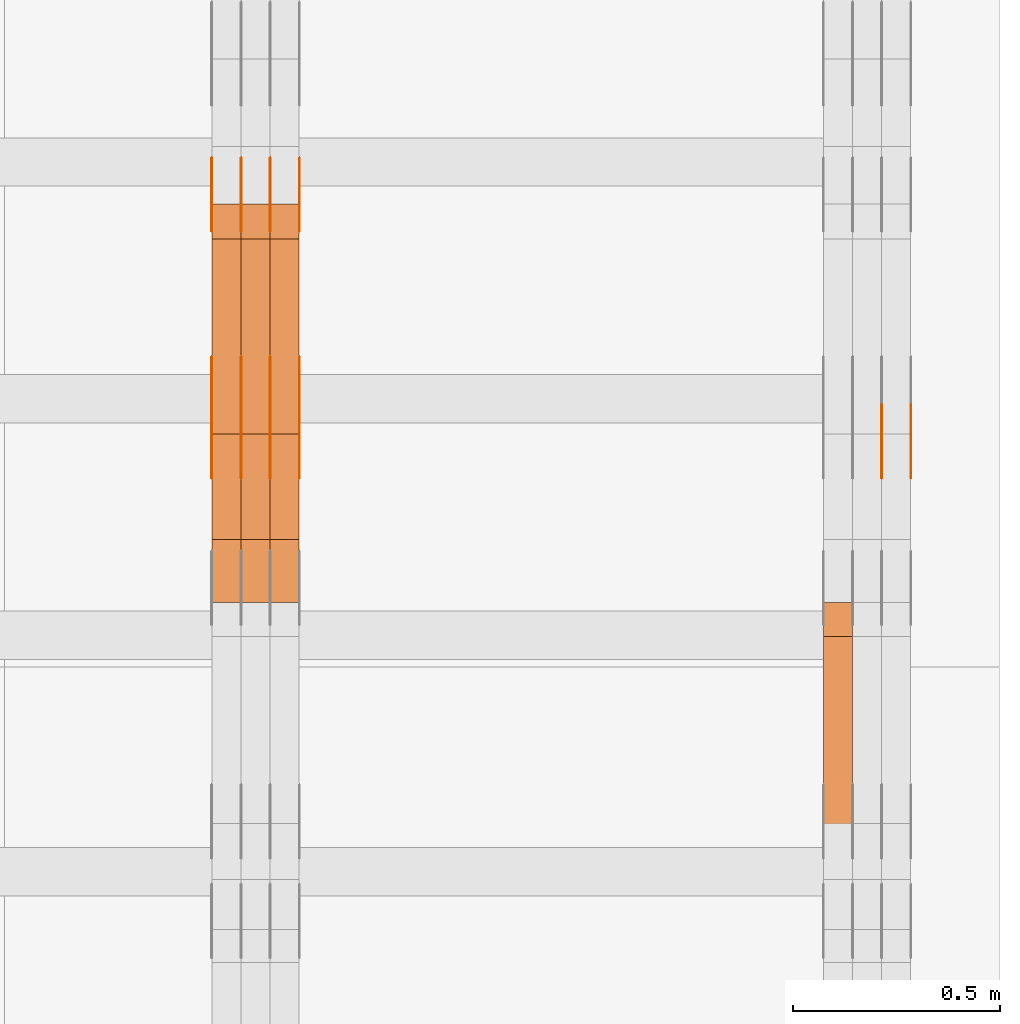
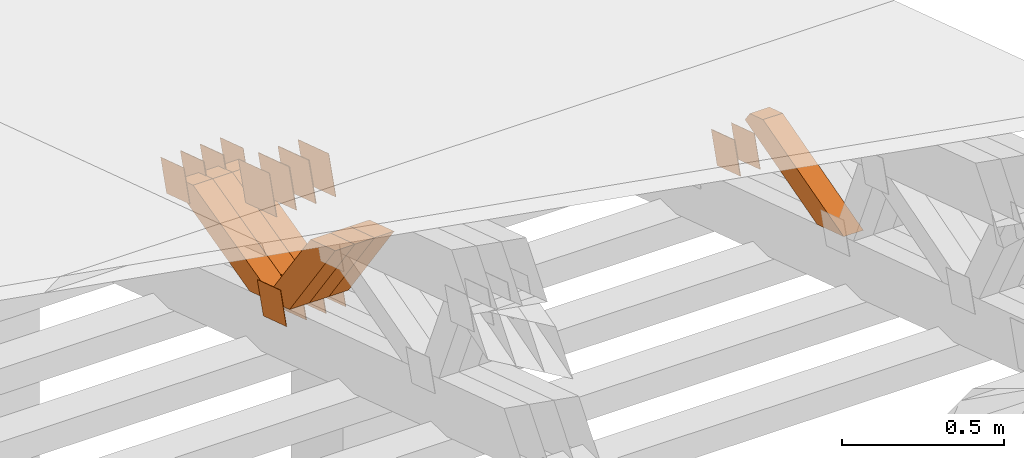
# One storey, part 373 of 385: 28 proxies.
"""IFC2X3 building model written with IfcOpenShell, lengths in millimetres."""

from ifc_helpers import new_model, entity, si_unit, converted_unit, derived_unit, direction, frame, origin, place, context, subcontext, project, spatial, polyline, outline, extrude, source, transform, mapped, material, type_object, type_shapes, element, save


model = new_model("IFC2X3")

# Units and contexts
model_context = context("Model", 3, precision=0.01, world=origin(), true_north=direction((6.12303176911189e-17, 1.0)))
body_context = subcontext(model_context, "Body", "Model", "MODEL_VIEW")
ifc_project = project(units=[si_unit("LENGTHUNIT", "METRE", prefix="MILLI"), si_unit("AREAUNIT", "SQUARE_METRE"), si_unit("VOLUMEUNIT", "CUBIC_METRE"), converted_unit("PLANEANGLEUNIT", "DEGREE", entity("IfcRatioMeasure", 0.0174532925199433), si_unit("PLANEANGLEUNIT", "RADIAN"), dimensions=[0, 0, 0, 0, 0, 0, 0]), si_unit("MASSUNIT", "GRAM", prefix="KILO"), derived_unit("MASSDENSITYUNIT", [(si_unit("MASSUNIT", "GRAM", prefix="KILO"), 1), (si_unit("LENGTHUNIT", "METRE"), -3)]), si_unit("TIMEUNIT", "SECOND"), si_unit("FREQUENCYUNIT", "HERTZ"), si_unit("THERMODYNAMICTEMPERATUREUNIT", "DEGREE_CELSIUS"), derived_unit("THERMALTRANSMITTANCEUNIT", [(si_unit("MASSUNIT", "GRAM", prefix="KILO"), 1), (si_unit("THERMODYNAMICTEMPERATUREUNIT", "KELVIN"), -1), (si_unit("TIMEUNIT", "SECOND"), -3)]), derived_unit("VOLUMETRICFLOWRATEUNIT", [(si_unit("LENGTHUNIT", "METRE"), 3), (si_unit("TIMEUNIT", "SECOND"), -1)]), si_unit("ELECTRICCURRENTUNIT", "AMPERE"), si_unit("ELECTRICVOLTAGEUNIT", "VOLT"), si_unit("POWERUNIT", "WATT"), si_unit("FORCEUNIT", "NEWTON", prefix="KILO"), si_unit("ILLUMINANCEUNIT", "LUX"), si_unit("LUMINOUSFLUXUNIT", "LUMEN"), si_unit("LUMINOUSINTENSITYUNIT", "CANDELA"), derived_unit("USERDEFINED", [(si_unit("MASSUNIT", "GRAM", prefix="KILO"), -1), (si_unit("LENGTHUNIT", "METRE"), -2), (si_unit("TIMEUNIT", "SECOND"), 3), (si_unit("LUMINOUSFLUXUNIT", "LUMEN"), 1)]), derived_unit("LINEARVELOCITYUNIT", [(si_unit("LENGTHUNIT", "METRE"), 1), (si_unit("TIMEUNIT", "SECOND"), -1)]), si_unit("PRESSUREUNIT", "PASCAL"), derived_unit("USERDEFINED", [(si_unit("LENGTHUNIT", "METRE"), -2), (si_unit("MASSUNIT", "GRAM", prefix="KILO"), 1), (si_unit("TIMEUNIT", "SECOND"), -2)])], contexts=[model_context])

# Site, building, storey
site_placement = place(None, origin())
site = spatial("IfcSite", under=ifc_project, at=site_placement, CompositionType="ELEMENT")
building_placement = place(site_placement, origin())
building = spatial("IfcBuilding", under=site, at=building_placement, CompositionType="ELEMENT")
storey_placement = place(building_placement, origin())
storey = spatial("IfcBuildingStorey", under=building, at=storey_placement, Name="Default", CompositionType="ELEMENT", Elevation=0.0)

# Proxies
ifc_material_1 = material(Name="IfcSurfaceStyle #608302")
building_element_proxy_type_1 = type_object("IfcBuildingElementProxyType", PredefinedType="NOTDEFINED", material=ifc_material_1)
shared_shape_1 = source(origin(), body_context, "Body", "SweptSolid", [
    extrude(outline(polyline([(-74.9998841352385, -59.9999554917014), (74.9998707133932, -59.9999554917014), (74.999874704788, 59.9999554917014), (-74.9998612829427, 59.9999554917014), (-74.9998841352385, -59.9999554917014)])), frame((75.0000802775471, 60.0000306612849, 0.0), z_axis=(0.0, 0.0, 1.0), x_axis=(-1.0, 0.0, 0.0)), (0.0, 0.0, 1.0), 1.3),
])
type_shapes(building_element_proxy_type_1, [shared_shape_1])
proxy_1_placement = place(building_placement, frame((49861.3, 24338.8869142613, 728.405515087805), z_axis=(-1.0, 0.0, 0.0), x_axis=(0.0, -0.951056516295124, 0.309016994375039)))
element("IfcBuildingElementProxy", 1, at=proxy_1_placement, inside=storey, type_object=building_element_proxy_type_1, material=ifc_material_1, context=body_context, shape_type="MappedRepresentation", body=[
    mapped(shared_shape_1, transform((0.0, 0.0, 0.0), scale=1.0)),
])
ifc_material_2 = material(Name="IfcSurfaceStyle #608245")
building_element_proxy_type_2 = type_object("IfcBuildingElementProxyType", PredefinedType="NOTDEFINED", material=ifc_material_2)
shared_shape_2 = source(origin(), body_context, "Body", "SweptSolid", [
    extrude(outline(polyline([(-74.9998841352385, -59.9999554917014), (74.9998707133932, -59.9999554917014), (74.999874704788, 59.9999554917014), (-74.9998612829427, 59.9999554917014), (-74.9998841352385, -59.9999554917014)])), frame((75.0000802775471, 60.0000306612849, 0.0), z_axis=(0.0, 0.0, 1.0), x_axis=(-1.0, 0.0, 0.0)), (0.0, 0.0, 1.0), 1.3),
])
type_shapes(building_element_proxy_type_2, [shared_shape_2])
proxy_2_placement = place(building_placement, frame((49790.0, 24338.8869142613, 728.405515087805), z_axis=(-1.0, 0.0, 0.0), x_axis=(0.0, -0.951056516295124, 0.309016994375039)))
element("IfcBuildingElementProxy", 2, at=proxy_2_placement, inside=storey, type_object=building_element_proxy_type_2, material=ifc_material_2, context=body_context, shape_type="MappedRepresentation", body=[
    mapped(shared_shape_2, transform((0.0, 0.0, 0.0), scale=1.0)),
])
ifc_material_3 = material(Name="IfcSurfaceStyle #608188")
building_element_proxy_type_3 = type_object("IfcBuildingElementProxyType", PredefinedType="NOTDEFINED", material=ifc_material_3)
shared_shape_3 = source(origin(), body_context, "Body", "SweptSolid", [
    extrude(outline(polyline([(-74.9998841352385, -59.9999554917014), (74.9998707133932, -59.9999554917014), (74.999874704788, 59.9999554917014), (-74.9998612829427, 59.9999554917014), (-74.9998841352385, -59.9999554917014)])), frame((75.0000802775471, 60.0000306612849, 0.0), z_axis=(0.0, 0.0, 1.0), x_axis=(-1.0, 0.0, 0.0)), (0.0, 0.0, 1.0), 1.3),
])
type_shapes(building_element_proxy_type_3, [shared_shape_3])
proxy_3_placement = place(building_placement, frame((49791.3, 24338.8869142613, 728.405515087805), z_axis=(-1.0, 0.0, 0.0), x_axis=(0.0, -0.951056516295124, 0.309016994375039)))
element("IfcBuildingElementProxy", 3, at=proxy_3_placement, inside=storey, type_object=building_element_proxy_type_3, material=ifc_material_3, context=body_context, shape_type="MappedRepresentation", body=[
    mapped(shared_shape_3, transform((0.0, 0.0, 0.0), scale=1.0)),
])
ifc_material_4 = material(Name="IfcSurfaceStyle #596290")
building_element_proxy_type_4 = type_object("IfcBuildingElementProxyType", Name="T2-W16 596288", PredefinedType="NOTDEFINED", material=ifc_material_4)
shared_shape_4 = source(origin(), body_context, "Body", "SweptSolid", [
    extrude(outline(polyline([(-370.757125176074, -47.4999438400901), (145.934648032773, -47.4999438400902), (217.511780472151, -4.11857860007858e-05), (234.91308660316, 47.4999644329832), (-227.602389932009, 47.4999644329832), (-370.757125176074, -47.4999438400901)])), frame((234.913162148205, 47.5000075544853, 0.0), z_axis=(0.0, 0.0, 1.0), x_axis=(-1.0, 0.0, 0.0)), (0.0, 0.0, 1.0), 70.0),
])
type_shapes(building_element_proxy_type_4, [shared_shape_4])
proxy_4_placement = place(building_placement, frame((49720.0, 23927.1704945031, 1199.43003244777), z_axis=(-1.0, 0.0, 0.0), x_axis=(0.0, -0.963308155550006, -0.268397834288666)))
element("IfcBuildingElementProxy", 4, at=proxy_4_placement, inside=storey, type_object=building_element_proxy_type_4, material=ifc_material_4, Name="T2-W16", context=body_context, shape_type="MappedRepresentation", body=[
    mapped(shared_shape_4, transform((0.0, 0.0, 0.0), scale=1.0)),
])
ifc_material_5 = material(Name="IfcSurfaceStyle #573870")
building_element_proxy_type_5 = type_object("IfcBuildingElementProxyType", PredefinedType="NOTDEFINED", material=ifc_material_5)
shared_shape_5 = source(origin(), body_context, "Body", "SweptSolid", [
    extrude(outline(polyline([(-74.9998841352385, -59.9999554917014), (74.9998707133932, -59.9999554917014), (74.999874704788, 59.9999554917014), (-74.9998612829427, 59.9999554917014), (-74.9998841352385, -59.9999554917014)])), frame((75.0000802775471, 60.0000306612849, 0.0), z_axis=(0.0, 0.0, 1.0), x_axis=(-1.0, 0.0, 0.0)), (0.0, 0.0, 1.0), 1.3),
])
type_shapes(building_element_proxy_type_5, [shared_shape_5])
proxy_5_placement = place(building_placement, frame((48386.3, 24338.8869142613, 728.405515087805), z_axis=(-1.0, 0.0, 0.0), x_axis=(0.0, -0.951056516295124, 0.309016994375039)))
element("IfcBuildingElementProxy", 5, at=proxy_5_placement, inside=storey, type_object=building_element_proxy_type_5, material=ifc_material_5, context=body_context, shape_type="MappedRepresentation", body=[
    mapped(shared_shape_5, transform((0.0, 0.0, 0.0), scale=1.0)),
])
ifc_material_6 = material(Name="IfcSurfaceStyle #573813")
building_element_proxy_type_6 = type_object("IfcBuildingElementProxyType", PredefinedType="NOTDEFINED", material=ifc_material_6)
shared_shape_6 = source(origin(), body_context, "Body", "SweptSolid", [
    extrude(outline(polyline([(-74.9998841352385, -59.9999554917014), (74.9998707133932, -59.9999554917014), (74.999874704788, 59.9999554917014), (-74.9998612829427, 59.9999554917014), (-74.9998841352385, -59.9999554917014)])), frame((75.0000802775471, 60.0000306612849, 0.0), z_axis=(0.0, 0.0, 1.0), x_axis=(-1.0, 0.0, 0.0)), (0.0, 0.0, 1.0), 1.3),
])
type_shapes(building_element_proxy_type_6, [shared_shape_6])
proxy_6_placement = place(building_placement, frame((48315.0, 24338.8869142613, 728.405515087805), z_axis=(-1.0, 0.0, 0.0), x_axis=(0.0, -0.951056516295124, 0.309016994375039)))
element("IfcBuildingElementProxy", 6, at=proxy_6_placement, inside=storey, type_object=building_element_proxy_type_6, material=ifc_material_6, context=body_context, shape_type="MappedRepresentation", body=[
    mapped(shared_shape_6, transform((0.0, 0.0, 0.0), scale=1.0)),
])
ifc_material_7 = material(Name="IfcSurfaceStyle #573756")
building_element_proxy_type_7 = type_object("IfcBuildingElementProxyType", PredefinedType="NOTDEFINED", material=ifc_material_7)
shared_shape_7 = source(origin(), body_context, "Body", "SweptSolid", [
    extrude(outline(polyline([(-74.9998841352385, -59.9999554917014), (74.9998707133932, -59.9999554917014), (74.999874704788, 59.9999554917014), (-74.9998612829427, 59.9999554917014), (-74.9998841352385, -59.9999554917014)])), frame((75.0000802775471, 60.0000306612849, 0.0), z_axis=(0.0, 0.0, 1.0), x_axis=(-1.0, 0.0, 0.0)), (0.0, 0.0, 1.0), 1.3),
])
type_shapes(building_element_proxy_type_7, [shared_shape_7])
proxy_7_placement = place(building_placement, frame((48316.3, 24338.8869142613, 728.405515087805), z_axis=(-1.0, 0.0, 0.0), x_axis=(0.0, -0.951056516295124, 0.309016994375039)))
element("IfcBuildingElementProxy", 7, at=proxy_7_placement, inside=storey, type_object=building_element_proxy_type_7, material=ifc_material_7, context=body_context, shape_type="MappedRepresentation", body=[
    mapped(shared_shape_7, transform((0.0, 0.0, 0.0), scale=1.0)),
])
ifc_material_8 = material(Name="IfcSurfaceStyle #573699")
building_element_proxy_type_8 = type_object("IfcBuildingElementProxyType", PredefinedType="NOTDEFINED", material=ifc_material_8)
shared_shape_8 = source(origin(), body_context, "Body", "SweptSolid", [
    extrude(outline(polyline([(-74.9998841352385, -59.9999554917014), (74.9998707133932, -59.9999554917014), (74.999874704788, 59.9999554917014), (-74.9998612829427, 59.9999554917014), (-74.9998841352385, -59.9999554917014)])), frame((75.0000802775471, 60.0000306612849, 0.0), z_axis=(0.0, 0.0, 1.0), x_axis=(-1.0, 0.0, 0.0)), (0.0, 0.0, 1.0), 1.29999999999999),
])
type_shapes(building_element_proxy_type_8, [shared_shape_8])
proxy_8_placement = place(building_placement, frame((48245.0, 24338.8869142613, 728.405515087805), z_axis=(-1.0, 0.0, 0.0), x_axis=(0.0, -0.951056516295124, 0.309016994375039)))
element("IfcBuildingElementProxy", 8, at=proxy_8_placement, inside=storey, type_object=building_element_proxy_type_8, material=ifc_material_8, context=body_context, shape_type="MappedRepresentation", body=[
    mapped(shared_shape_8, transform((0.0, 0.0, 0.0), scale=1.0)),
])
ifc_material_9 = material(Name="IfcSurfaceStyle #573642")
building_element_proxy_type_9 = type_object("IfcBuildingElementProxyType", PredefinedType="NOTDEFINED", material=ifc_material_9)
shared_shape_9 = source(origin(), body_context, "Body", "SweptSolid", [
    extrude(outline(polyline([(-74.9998841352385, -59.9999554917014), (74.9998707133932, -59.9999554917014), (74.999874704788, 59.9999554917014), (-74.9998612829427, 59.9999554917014), (-74.9998841352385, -59.9999554917014)])), frame((75.0000802775471, 60.0000306612849, 0.0), z_axis=(0.0, 0.0, 1.0), x_axis=(-1.0, 0.0, 0.0)), (0.0, 0.0, 1.0), 1.29999999999999),
])
type_shapes(building_element_proxy_type_9, [shared_shape_9])
proxy_9_placement = place(building_placement, frame((48246.3, 24338.8869142613, 728.405515087805), z_axis=(-1.0, 0.0, 0.0), x_axis=(0.0, -0.951056516295124, 0.309016994375039)))
element("IfcBuildingElementProxy", 9, at=proxy_9_placement, inside=storey, type_object=building_element_proxy_type_9, material=ifc_material_9, context=body_context, shape_type="MappedRepresentation", body=[
    mapped(shared_shape_9, transform((0.0, 0.0, 0.0), scale=1.0)),
])
ifc_material_10 = material(Name="IfcSurfaceStyle #573585")
building_element_proxy_type_10 = type_object("IfcBuildingElementProxyType", PredefinedType="NOTDEFINED", material=ifc_material_10)
shared_shape_10 = source(origin(), body_context, "Body", "SweptSolid", [
    extrude(outline(polyline([(-74.9998841352385, -59.9999554917014), (74.9998707133932, -59.9999554917014), (74.999874704788, 59.9999554917014), (-74.9998612829427, 59.9999554917014), (-74.9998841352385, -59.9999554917014)])), frame((75.0000802775471, 60.0000306612849, 0.0), z_axis=(0.0, 0.0, 1.0), x_axis=(-1.0, 0.0, 0.0)), (0.0, 0.0, 1.0), 1.29999999999999),
])
type_shapes(building_element_proxy_type_10, [shared_shape_10])
proxy_10_placement = place(building_placement, frame((48175.0, 24338.8869142613, 728.405515087805), z_axis=(-1.0, 0.0, 0.0), x_axis=(0.0, -0.951056516295124, 0.309016994375039)))
element("IfcBuildingElementProxy", 10, at=proxy_10_placement, inside=storey, type_object=building_element_proxy_type_10, material=ifc_material_10, context=body_context, shape_type="MappedRepresentation", body=[
    mapped(shared_shape_10, transform((0.0, 0.0, 0.0), scale=1.0)),
])
ifc_material_11 = material(Name="IfcSurfaceStyle #573186")
building_element_proxy_type_11 = type_object("IfcBuildingElementProxyType", PredefinedType="NOTDEFINED", material=ifc_material_11)
shared_shape_11 = source(origin(), body_context, "Body", "SweptSolid", [
    extrude(outline(polyline([(-75.0001163267648, -60.0000309352964), (75.0001029049313, -60.0000309352964), (75.0001068963143, 60.0000309352964), (-75.0000934744807, 60.0000309352964), (-75.0001163267648, -60.0000309352964)])), frame((75.0001143227305, 60.0000309352964, 0.0), z_axis=(0.0, 0.0, 1.0), x_axis=(-1.0, 0.0, 0.0)), (0.0, 0.0, 1.0), 1.3),
])
type_shapes(building_element_proxy_type_11, [shared_shape_11])
proxy_11_placement = place(building_placement, frame((48386.3, 24935.0160969462, 827.753587802763), z_axis=(-1.0, 0.0, 0.0), x_axis=(0.0, -0.951056516295154, 0.309016994374948)))
element("IfcBuildingElementProxy", 11, at=proxy_11_placement, inside=storey, type_object=building_element_proxy_type_11, material=ifc_material_11, context=body_context, shape_type="MappedRepresentation", body=[
    mapped(shared_shape_11, transform((0.0, 0.0, 0.0), scale=1.0)),
])
ifc_material_12 = material(Name="IfcSurfaceStyle #573129")
building_element_proxy_type_12 = type_object("IfcBuildingElementProxyType", PredefinedType="NOTDEFINED", material=ifc_material_12)
shared_shape_12 = source(origin(), body_context, "Body", "SweptSolid", [
    extrude(outline(polyline([(-75.0001163267648, -60.0000309352964), (75.0001029049313, -60.0000309352964), (75.0001068963143, 60.0000309352964), (-75.0000934744807, 60.0000309352964), (-75.0001163267648, -60.0000309352964)])), frame((75.0001143227305, 60.0000309352964, 0.0), z_axis=(0.0, 0.0, 1.0), x_axis=(-1.0, 0.0, 0.0)), (0.0, 0.0, 1.0), 1.3),
])
type_shapes(building_element_proxy_type_12, [shared_shape_12])
proxy_12_placement = place(building_placement, frame((48315.0, 24935.0160969462, 827.753587802763), z_axis=(-1.0, 0.0, 0.0), x_axis=(0.0, -0.951056516295154, 0.309016994374948)))
element("IfcBuildingElementProxy", 12, at=proxy_12_placement, inside=storey, type_object=building_element_proxy_type_12, material=ifc_material_12, context=body_context, shape_type="MappedRepresentation", body=[
    mapped(shared_shape_12, transform((0.0, 0.0, 0.0), scale=1.0)),
])
ifc_material_13 = material(Name="IfcSurfaceStyle #573072")
building_element_proxy_type_13 = type_object("IfcBuildingElementProxyType", PredefinedType="NOTDEFINED", material=ifc_material_13)
shared_shape_13 = source(origin(), body_context, "Body", "SweptSolid", [
    extrude(outline(polyline([(-75.0001163267648, -60.0000309352964), (75.0001029049313, -60.0000309352964), (75.0001068963143, 60.0000309352964), (-75.0000934744807, 60.0000309352964), (-75.0001163267648, -60.0000309352964)])), frame((75.0001143227305, 60.0000309352964, 0.0), z_axis=(0.0, 0.0, 1.0), x_axis=(-1.0, 0.0, 0.0)), (0.0, 0.0, 1.0), 1.3),
])
type_shapes(building_element_proxy_type_13, [shared_shape_13])
proxy_13_placement = place(building_placement, frame((48316.3, 24935.0160969462, 827.753587802763), z_axis=(-1.0, 0.0, 0.0), x_axis=(0.0, -0.951056516295154, 0.309016994374948)))
element("IfcBuildingElementProxy", 13, at=proxy_13_placement, inside=storey, type_object=building_element_proxy_type_13, material=ifc_material_13, context=body_context, shape_type="MappedRepresentation", body=[
    mapped(shared_shape_13, transform((0.0, 0.0, 0.0), scale=1.0)),
])
ifc_material_14 = material(Name="IfcSurfaceStyle #573015")
building_element_proxy_type_14 = type_object("IfcBuildingElementProxyType", PredefinedType="NOTDEFINED", material=ifc_material_14)
shared_shape_14 = source(origin(), body_context, "Body", "SweptSolid", [
    extrude(outline(polyline([(-75.0001163267648, -60.0000309352964), (75.0001029049313, -60.0000309352964), (75.0001068963143, 60.0000309352964), (-75.0000934744807, 60.0000309352964), (-75.0001163267648, -60.0000309352964)])), frame((75.0001143227305, 60.0000309352964, 0.0), z_axis=(0.0, 0.0, 1.0), x_axis=(-1.0, 0.0, 0.0)), (0.0, 0.0, 1.0), 1.29999999999999),
])
type_shapes(building_element_proxy_type_14, [shared_shape_14])
proxy_14_placement = place(building_placement, frame((48245.0, 24935.0160969462, 827.753587802763), z_axis=(-1.0, 0.0, 0.0), x_axis=(0.0, -0.951056516295154, 0.309016994374948)))
element("IfcBuildingElementProxy", 14, at=proxy_14_placement, inside=storey, type_object=building_element_proxy_type_14, material=ifc_material_14, context=body_context, shape_type="MappedRepresentation", body=[
    mapped(shared_shape_14, transform((0.0, 0.0, 0.0), scale=1.0)),
])
ifc_material_15 = material(Name="IfcSurfaceStyle #572958")
building_element_proxy_type_15 = type_object("IfcBuildingElementProxyType", PredefinedType="NOTDEFINED", material=ifc_material_15)
shared_shape_15 = source(origin(), body_context, "Body", "SweptSolid", [
    extrude(outline(polyline([(-75.0001163267648, -60.0000309352964), (75.0001029049313, -60.0000309352964), (75.0001068963143, 60.0000309352964), (-75.0000934744807, 60.0000309352964), (-75.0001163267648, -60.0000309352964)])), frame((75.0001143227305, 60.0000309352964, 0.0), z_axis=(0.0, 0.0, 1.0), x_axis=(-1.0, 0.0, 0.0)), (0.0, 0.0, 1.0), 1.29999999999999),
])
type_shapes(building_element_proxy_type_15, [shared_shape_15])
proxy_15_placement = place(building_placement, frame((48246.3, 24935.0160969462, 827.753587802763), z_axis=(-1.0, 0.0, 0.0), x_axis=(0.0, -0.951056516295154, 0.309016994374948)))
element("IfcBuildingElementProxy", 15, at=proxy_15_placement, inside=storey, type_object=building_element_proxy_type_15, material=ifc_material_15, context=body_context, shape_type="MappedRepresentation", body=[
    mapped(shared_shape_15, transform((0.0, 0.0, 0.0), scale=1.0)),
])
ifc_material_16 = material(Name="IfcSurfaceStyle #572901")
building_element_proxy_type_16 = type_object("IfcBuildingElementProxyType", PredefinedType="NOTDEFINED", material=ifc_material_16)
shared_shape_16 = source(origin(), body_context, "Body", "SweptSolid", [
    extrude(outline(polyline([(-75.0001163267648, -60.0000309352964), (75.0001029049313, -60.0000309352964), (75.0001068963143, 60.0000309352964), (-75.0000934744807, 60.0000309352964), (-75.0001163267648, -60.0000309352964)])), frame((75.0001143227305, 60.0000309352964, 0.0), z_axis=(0.0, 0.0, 1.0), x_axis=(-1.0, 0.0, 0.0)), (0.0, 0.0, 1.0), 1.29999999999999),
])
type_shapes(building_element_proxy_type_16, [shared_shape_16])
proxy_16_placement = place(building_placement, frame((48175.0, 24935.0160969462, 827.753587802763), z_axis=(-1.0, 0.0, 0.0), x_axis=(0.0, -0.951056516295154, 0.309016994374948)))
element("IfcBuildingElementProxy", 16, at=proxy_16_placement, inside=storey, type_object=building_element_proxy_type_16, material=ifc_material_16, context=body_context, shape_type="MappedRepresentation", body=[
    mapped(shared_shape_16, transform((0.0, 0.0, 0.0), scale=1.0)),
])
ifc_material_17 = material(Name="IfcSurfaceStyle #570792")
building_element_proxy_type_17 = type_object("IfcBuildingElementProxyType", PredefinedType="NOTDEFINED", material=ifc_material_17)
shared_shape_17 = source(origin(), body_context, "Body", "SweptSolid", [
    extrude(outline(polyline([(-100.000009625089, -72.0000630699202), (100.000090167682, -72.0000630699202), (100.000009625089, 72.0000630699202), (-100.000090167682, 72.0000630699202), (-100.000009625089, -72.0000630699202)])), frame((100.000090167682, 72.0000630699202, 0.0), z_axis=(0.0, 0.0, 1.0), x_axis=(-1.0, 0.0, 0.0)), (0.0, 0.0, 1.0), 1.3),
])
type_shapes(building_element_proxy_type_17, [shared_shape_17])
proxy_17_placement = place(building_placement, frame((48386.3, 24447.7695802369, 1088.58717039832), z_axis=(-1.0, 0.0, 0.0), x_axis=(0.0, -0.951056516295154, 0.309016994374948)))
element("IfcBuildingElementProxy", 17, at=proxy_17_placement, inside=storey, type_object=building_element_proxy_type_17, material=ifc_material_17, context=body_context, shape_type="MappedRepresentation", body=[
    mapped(shared_shape_17, transform((0.0, 0.0, 0.0), scale=1.0)),
])
ifc_material_18 = material(Name="IfcSurfaceStyle #570735")
building_element_proxy_type_18 = type_object("IfcBuildingElementProxyType", PredefinedType="NOTDEFINED", material=ifc_material_18)
shared_shape_18 = source(origin(), body_context, "Body", "SweptSolid", [
    extrude(outline(polyline([(-100.000009625089, -72.0000630699202), (100.000090167682, -72.0000630699202), (100.000009625089, 72.0000630699202), (-100.000090167682, 72.0000630699202), (-100.000009625089, -72.0000630699202)])), frame((100.000090167682, 72.0000630699202, 0.0), z_axis=(0.0, 0.0, 1.0), x_axis=(-1.0, 0.0, 0.0)), (0.0, 0.0, 1.0), 1.3),
])
type_shapes(building_element_proxy_type_18, [shared_shape_18])
proxy_18_placement = place(building_placement, frame((48315.0, 24447.7695802369, 1088.58717039832), z_axis=(-1.0, 0.0, 0.0), x_axis=(0.0, -0.951056516295154, 0.309016994374948)))
element("IfcBuildingElementProxy", 18, at=proxy_18_placement, inside=storey, type_object=building_element_proxy_type_18, material=ifc_material_18, context=body_context, shape_type="MappedRepresentation", body=[
    mapped(shared_shape_18, transform((0.0, 0.0, 0.0), scale=1.0)),
])
ifc_material_19 = material(Name="IfcSurfaceStyle #570678")
building_element_proxy_type_19 = type_object("IfcBuildingElementProxyType", PredefinedType="NOTDEFINED", material=ifc_material_19)
shared_shape_19 = source(origin(), body_context, "Body", "SweptSolid", [
    extrude(outline(polyline([(-100.000009625089, -72.0000630699202), (100.000090167682, -72.0000630699202), (100.000009625089, 72.0000630699202), (-100.000090167682, 72.0000630699202), (-100.000009625089, -72.0000630699202)])), frame((100.000090167682, 72.0000630699202, 0.0), z_axis=(0.0, 0.0, 1.0), x_axis=(-1.0, 0.0, 0.0)), (0.0, 0.0, 1.0), 1.3),
])
type_shapes(building_element_proxy_type_19, [shared_shape_19])
proxy_19_placement = place(building_placement, frame((48316.3, 24447.7695802369, 1088.58717039832), z_axis=(-1.0, 0.0, 0.0), x_axis=(0.0, -0.951056516295154, 0.309016994374948)))
element("IfcBuildingElementProxy", 19, at=proxy_19_placement, inside=storey, type_object=building_element_proxy_type_19, material=ifc_material_19, context=body_context, shape_type="MappedRepresentation", body=[
    mapped(shared_shape_19, transform((0.0, 0.0, 0.0), scale=1.0)),
])
ifc_material_20 = material(Name="IfcSurfaceStyle #570621")
building_element_proxy_type_20 = type_object("IfcBuildingElementProxyType", PredefinedType="NOTDEFINED", material=ifc_material_20)
shared_shape_20 = source(origin(), body_context, "Body", "SweptSolid", [
    extrude(outline(polyline([(-100.000009625089, -72.0000630699202), (100.000090167682, -72.0000630699202), (100.000009625089, 72.0000630699202), (-100.000090167682, 72.0000630699202), (-100.000009625089, -72.0000630699202)])), frame((100.000090167682, 72.0000630699202, 0.0), z_axis=(0.0, 0.0, 1.0), x_axis=(-1.0, 0.0, 0.0)), (0.0, 0.0, 1.0), 1.29999999999998),
])
type_shapes(building_element_proxy_type_20, [shared_shape_20])
proxy_20_placement = place(building_placement, frame((48245.0, 24447.7695802369, 1088.58717039832), z_axis=(-1.0, 0.0, 0.0), x_axis=(0.0, -0.951056516295154, 0.309016994374948)))
element("IfcBuildingElementProxy", 20, at=proxy_20_placement, inside=storey, type_object=building_element_proxy_type_20, material=ifc_material_20, context=body_context, shape_type="MappedRepresentation", body=[
    mapped(shared_shape_20, transform((0.0, 0.0, 0.0), scale=1.0)),
])
ifc_material_21 = material(Name="IfcSurfaceStyle #570564")
building_element_proxy_type_21 = type_object("IfcBuildingElementProxyType", PredefinedType="NOTDEFINED", material=ifc_material_21)
shared_shape_21 = source(origin(), body_context, "Body", "SweptSolid", [
    extrude(outline(polyline([(-100.000009625089, -72.0000630699202), (100.000090167682, -72.0000630699202), (100.000009625089, 72.0000630699202), (-100.000090167682, 72.0000630699202), (-100.000009625089, -72.0000630699202)])), frame((100.000090167682, 72.0000630699202, 0.0), z_axis=(0.0, 0.0, 1.0), x_axis=(-1.0, 0.0, 0.0)), (0.0, 0.0, 1.0), 1.29999999999998),
])
type_shapes(building_element_proxy_type_21, [shared_shape_21])
proxy_21_placement = place(building_placement, frame((48246.3, 24447.7695802369, 1088.58717039832), z_axis=(-1.0, 0.0, 0.0), x_axis=(0.0, -0.951056516295154, 0.309016994374948)))
element("IfcBuildingElementProxy", 21, at=proxy_21_placement, inside=storey, type_object=building_element_proxy_type_21, material=ifc_material_21, context=body_context, shape_type="MappedRepresentation", body=[
    mapped(shared_shape_21, transform((0.0, 0.0, 0.0), scale=1.0)),
])
ifc_material_22 = material(Name="IfcSurfaceStyle #570507")
building_element_proxy_type_22 = type_object("IfcBuildingElementProxyType", PredefinedType="NOTDEFINED", material=ifc_material_22)
shared_shape_22 = source(origin(), body_context, "Body", "SweptSolid", [
    extrude(outline(polyline([(-100.000009625089, -72.0000630699202), (100.000090167682, -72.0000630699202), (100.000009625089, 72.0000630699202), (-100.000090167682, 72.0000630699202), (-100.000009625089, -72.0000630699202)])), frame((100.000090167682, 72.0000630699202, 0.0), z_axis=(0.0, 0.0, 1.0), x_axis=(-1.0, 0.0, 0.0)), (0.0, 0.0, 1.0), 1.29999999999999),
])
type_shapes(building_element_proxy_type_22, [shared_shape_22])
proxy_22_placement = place(building_placement, frame((48175.0, 24447.7695802369, 1088.58717039832), z_axis=(-1.0, 0.0, 0.0), x_axis=(0.0, -0.951056516295154, 0.309016994374948)))
element("IfcBuildingElementProxy", 22, at=proxy_22_placement, inside=storey, type_object=building_element_proxy_type_22, material=ifc_material_22, context=body_context, shape_type="MappedRepresentation", body=[
    mapped(shared_shape_22, transform((0.0, 0.0, 0.0), scale=1.0)),
])
ifc_material_23 = material(Name="IfcSurfaceStyle #561594")
building_element_proxy_type_23 = type_object("IfcBuildingElementProxyType", Name="T1-W24 561592", PredefinedType="NOTDEFINED", material=ifc_material_23)
shared_shape_23 = source(origin(), body_context, "Body", "SweptSolid", [
    extrude(outline(polyline([(-215.642157779899, -47.4998772343114), (220.829928576248, -47.4998772343114), (202.182343865616, 6.34871490324596e-05), (137.545638852774, 47.4998454907369), (-344.915753514738, 47.4998454907369), (-215.642157779899, -47.4998772343114)])), frame((220.830079609702, 47.500154567531, 0.0), z_axis=(0.0, 0.0, 1.0), x_axis=(-1.0, 0.0, 0.0)), (0.0, 0.0, 1.0), 70.0),
])
type_shapes(building_element_proxy_type_23, [shared_shape_23])
proxy_23_placement = place(building_placement, frame((48385.0, 24227.7045444998, 781.019082122604), z_axis=(-1.0, 0.0, 0.0), x_axis=(0.0, -0.583381854128324, 0.812198012970851)))
element("IfcBuildingElementProxy", 23, at=proxy_23_placement, inside=storey, type_object=building_element_proxy_type_23, material=ifc_material_23, Name="T1-W24", context=body_context, shape_type="MappedRepresentation", body=[
    mapped(shared_shape_23, transform((0.0, 0.0, 0.0), scale=1.0)),
])
ifc_material_24 = material(Name="IfcSurfaceStyle #561528")
building_element_proxy_type_24 = type_object("IfcBuildingElementProxyType", Name="T1-W24 561526", PredefinedType="NOTDEFINED", material=ifc_material_24)
shared_shape_24 = source(origin(), body_context, "Body", "SweptSolid", [
    extrude(outline(polyline([(-215.642157779899, -47.4998772343114), (220.829928576248, -47.4998772343114), (202.182343865616, 6.34871490324596e-05), (137.545638852774, 47.4998454907369), (-344.915753514738, 47.4998454907369), (-215.642157779899, -47.4998772343114)])), frame((220.830079609702, 47.500154567531, 0.0), z_axis=(0.0, 0.0, 1.0), x_axis=(-1.0, 0.0, 0.0)), (0.0, 0.0, 1.0), 70.0),
])
type_shapes(building_element_proxy_type_24, [shared_shape_24])
proxy_24_placement = place(building_placement, frame((48315.0, 24227.7045444998, 781.019082122604), z_axis=(-1.0, 0.0, 0.0), x_axis=(0.0, -0.583381854128324, 0.812198012970851)))
element("IfcBuildingElementProxy", 24, at=proxy_24_placement, inside=storey, type_object=building_element_proxy_type_24, material=ifc_material_24, Name="T1-W24", context=body_context, shape_type="MappedRepresentation", body=[
    mapped(shared_shape_24, transform((0.0, 0.0, 0.0), scale=1.0)),
])
ifc_material_25 = material(Name="IfcSurfaceStyle #561462")
building_element_proxy_type_25 = type_object("IfcBuildingElementProxyType", Name="T1-W24 561460", PredefinedType="NOTDEFINED", material=ifc_material_25)
shared_shape_25 = source(origin(), body_context, "Body", "SweptSolid", [
    extrude(outline(polyline([(-215.642157779899, -47.4998772343114), (220.829928576248, -47.4998772343114), (202.182343865616, 6.34871490324596e-05), (137.545638852774, 47.4998454907369), (-344.915753514738, 47.4998454907369), (-215.642157779899, -47.4998772343114)])), frame((220.830079609702, 47.500154567531, 0.0), z_axis=(0.0, 0.0, 1.0), x_axis=(-1.0, 0.0, 0.0)), (0.0, 0.0, 1.0), 70.0),
])
type_shapes(building_element_proxy_type_25, [shared_shape_25])
proxy_25_placement = place(building_placement, frame((48245.0, 24227.7045444998, 781.019082122604), z_axis=(-1.0, 0.0, 0.0), x_axis=(0.0, -0.583381854128324, 0.812198012970851)))
element("IfcBuildingElementProxy", 25, at=proxy_25_placement, inside=storey, type_object=building_element_proxy_type_25, material=ifc_material_25, Name="T1-W24", context=body_context, shape_type="MappedRepresentation", body=[
    mapped(shared_shape_25, transform((0.0, 0.0, 0.0), scale=1.0)),
])
ifc_material_26 = material(Name="IfcSurfaceStyle #561198")
building_element_proxy_type_26 = type_object("IfcBuildingElementProxyType", Name="T1-W13 561196", PredefinedType="NOTDEFINED", material=ifc_material_26)
shared_shape_26 = source(origin(), body_context, "Body", "SweptSolid", [
    extrude(outline(polyline([(-384.339592151497, -47.5000055308246), (150.996422207105, -47.5000055308247), (226.265349299398, -4.29484466835994e-05), (240.878612116891, 47.500027005048), (-233.800791471897, 47.500027005048), (-384.339592151497, -47.5000055308246)])), frame((240.878612116891, 47.500027005048, 0.0), z_axis=(0.0, 0.0, 1.0), x_axis=(-1.0, 0.0, 0.0)), (0.0, 0.0, 1.0), 70.0),
])
type_shapes(building_element_proxy_type_26, [shared_shape_26])
proxy_26_placement = place(building_placement, frame((48385.0, 24884.765625, 885.749145507813), z_axis=(-1.0, 0.0, 0.0), x_axis=(0.0, -0.969210894563555, -0.246232089418326)))
element("IfcBuildingElementProxy", 26, at=proxy_26_placement, inside=storey, type_object=building_element_proxy_type_26, material=ifc_material_26, Name="T1-W13", context=body_context, shape_type="MappedRepresentation", body=[
    mapped(shared_shape_26, transform((0.0, 0.0, 0.0), scale=1.0)),
])
ifc_material_27 = material(Name="IfcSurfaceStyle #561132")
building_element_proxy_type_27 = type_object("IfcBuildingElementProxyType", Name="T1-W13 561130", PredefinedType="NOTDEFINED", material=ifc_material_27)
shared_shape_27 = source(origin(), body_context, "Body", "SweptSolid", [
    extrude(outline(polyline([(-384.339592151497, -47.5000055308246), (150.996422207105, -47.5000055308247), (226.265349299398, -4.29484466835994e-05), (240.878612116891, 47.500027005048), (-233.800791471897, 47.500027005048), (-384.339592151497, -47.5000055308246)])), frame((240.878612116891, 47.500027005048, 0.0), z_axis=(0.0, 0.0, 1.0), x_axis=(-1.0, 0.0, 0.0)), (0.0, 0.0, 1.0), 70.0),
])
type_shapes(building_element_proxy_type_27, [shared_shape_27])
proxy_27_placement = place(building_placement, frame((48315.0, 24884.765625, 885.749145507813), z_axis=(-1.0, 0.0, 0.0), x_axis=(0.0, -0.969210894563555, -0.246232089418326)))
element("IfcBuildingElementProxy", 27, at=proxy_27_placement, inside=storey, type_object=building_element_proxy_type_27, material=ifc_material_27, Name="T1-W13", context=body_context, shape_type="MappedRepresentation", body=[
    mapped(shared_shape_27, transform((0.0, 0.0, 0.0), scale=1.0)),
])
ifc_material_28 = material(Name="IfcSurfaceStyle #561066")
building_element_proxy_type_28 = type_object("IfcBuildingElementProxyType", Name="T1-W13 561064", PredefinedType="NOTDEFINED", material=ifc_material_28)
shared_shape_28 = source(origin(), body_context, "Body", "SweptSolid", [
    extrude(outline(polyline([(-384.339592151497, -47.5000055308246), (150.996422207105, -47.5000055308247), (226.265349299398, -4.29484466835994e-05), (240.878612116891, 47.500027005048), (-233.800791471897, 47.500027005048), (-384.339592151497, -47.5000055308246)])), frame((240.878612116891, 47.500027005048, 0.0), z_axis=(0.0, 0.0, 1.0), x_axis=(-1.0, 0.0, 0.0)), (0.0, 0.0, 1.0), 70.0),
])
type_shapes(building_element_proxy_type_28, [shared_shape_28])
proxy_28_placement = place(building_placement, frame((48245.0, 24884.765625, 885.749145507813), z_axis=(-1.0, 0.0, 0.0), x_axis=(0.0, -0.969210894563555, -0.246232089418326)))
element("IfcBuildingElementProxy", 28, at=proxy_28_placement, inside=storey, type_object=building_element_proxy_type_28, material=ifc_material_28, Name="T1-W13", context=body_context, shape_type="MappedRepresentation", body=[
    mapped(shared_shape_28, transform((0.0, 0.0, 0.0), scale=1.0)),
])

save(model, "model.ifc")
